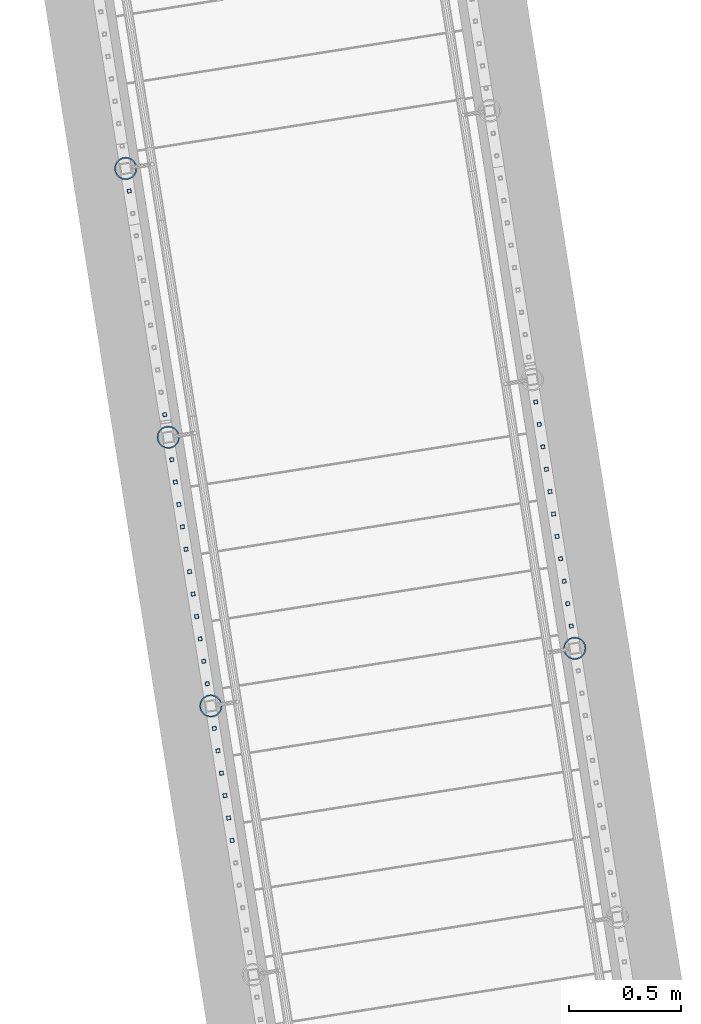
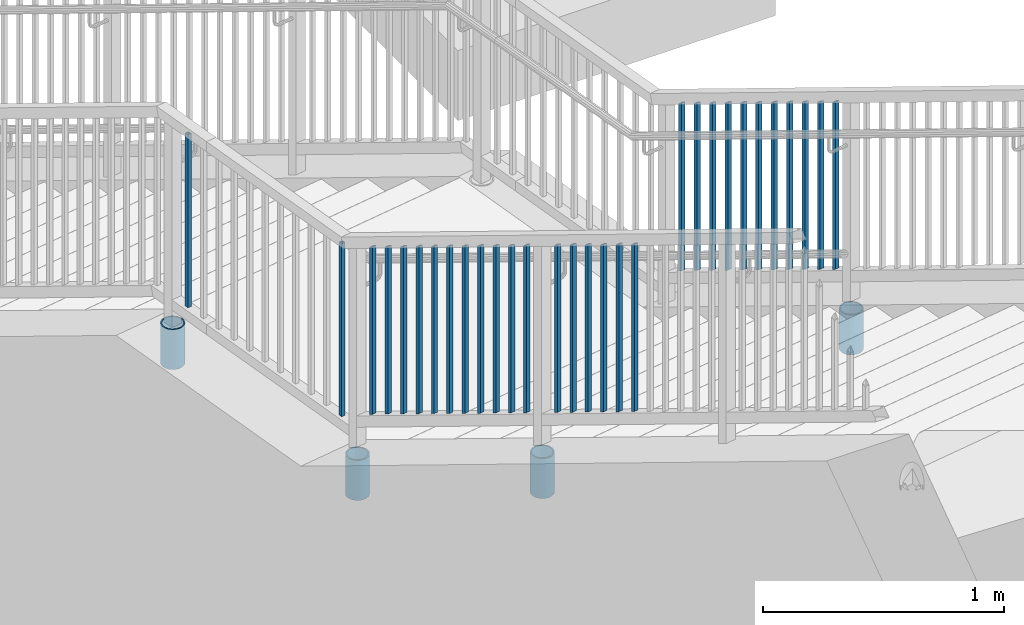
# One storey, part 225 of 975: 34 columns.
"""IFC2X3 building model written with IfcOpenShell, lengths in millimetres."""

from ifc_helpers import new_model, si_unit, frame, origin_with_axes, place, context, subcontext, project, spatial, faceted_brep, material, type_object, element, save


model = new_model("IFC2X3")

# Units and contexts
model_context = context("Model", 3, precision=1e-05, world=origin_with_axes())
body_context = subcontext(model_context, "Body", "Model", "MODEL_VIEW")
ifc_project = project(units=[si_unit("LENGTHUNIT", "METRE", prefix="MILLI"), si_unit("AREAUNIT", "SQUARE_METRE"), si_unit("VOLUMEUNIT", "CUBIC_METRE"), si_unit("MASSUNIT", "GRAM", prefix="KILO"), si_unit("TIMEUNIT", "SECOND"), si_unit("PLANEANGLEUNIT", "RADIAN"), si_unit("SOLIDANGLEUNIT", "STERADIAN"), si_unit("THERMODYNAMICTEMPERATUREUNIT", "DEGREE_CELSIUS"), si_unit("LUMINOUSINTENSITYUNIT", "LUMEN")], contexts=[model_context])

# Site, building, storey
site_placement = place(None, origin_with_axes())
site = spatial("IfcSite", under=ifc_project, at=site_placement, CompositionType="ELEMENT")
building_placement = place(site_placement, origin_with_axes())
building = spatial("IfcBuilding", under=site, at=building_placement, Name="Undefined", CompositionType="ELEMENT")
storey_placement = place(building_placement, origin_with_axes())
storey = spatial("IfcBuildingStorey", under=building, at=storey_placement, Name="Undefined", CompositionType="ELEMENT", Elevation=0.0)

# Columns
ifc_material_1 = material()
column_type_1 = type_object("IfcColumnType", Name="HSS3/4X3/4X.120_TUBES", PredefinedType="NOTDEFINED")
column_1_placement = place(storey_placement, frame((-2139.12873892956, 24109.8690795719, 2159.00006445516), z_axis=(-0.987688340611262, -0.156434464938429, 0.0), x_axis=(0.0, 0.0, 1.0)))
element("IfcColumn", 1, at=column_1_placement, inside=storey, type_object=column_type_1, material=ifc_material_1, Name="PICKET", ObjectType="HSS3/4X3/4X.120_TUBES", context=body_context, shape_type="Brep", body=[
    faceted_brep([(0.0, 6.34999999998763, -6.34999999998763), (0.0, -6.35000000000582, -6.34999999998763), (876.3, -6.35000000000218, -6.3500000000131), (876.3, 6.34999999999854, -6.35000000000946), (0.0, -6.34999999998763, 6.34999999998763), (876.3, -6.34999999999854, 6.34999999999127), (0.0, 6.35000000000946, 6.34999999998763), (876.3, 6.35000000000582, 6.34999999999491), (0.0, 9.52499999997963, -9.52499999997963), (0.0, 9.52500000000873, 9.5249999999869), (876.3, 9.52500000000146, 9.52499999999418), (876.3, 9.52499999999782, -9.52500000001237), (0.0, -9.52499999997963, 9.52499999998327), (876.3, -9.52499999999782, 9.52499999999054), (0.0, -9.52500000000873, -9.5249999999869), (876.3, -9.52500000000146, -9.52500000001237)], [[[0, 1, 2, 3]], [[1, 4, 5, 2]], [[4, 6, 7, 5]], [[6, 0, 3, 7]], [[8, 9, 10, 11]], [[9, 12, 13, 10]], [[12, 14, 15, 13]], [[14, 8, 11, 15]], [[13, 15, 11, 10], [5, 7, 3, 2]], [[14, 12, 9, 8], [6, 4, 1, 0]]]),
])
for number, where, z_axis, x_axis, name in (
    (2, (-317.339031692647, 23162.7377146644, 2852.79542413081), (-0.987688340611262, -0.156434464938429, 0.0), (0.0, 0.0, 1.0), "PICKET"),
    (3, (-333.241567261185, 23263.1423718248, 2796.67272117975), (-0.987688340611262, -0.156434464938429, 0.0), (0.0, 0.0, 1.0), "PICKET"),
    (4, (-349.144102829728, 23363.5470289853, 2740.55001822867), (-0.987688340611262, -0.156434464938429, 0.0), (0.0, 0.0, 1.0), "PICKET"),
    (5, (-365.046638398269, 23463.9516861457, 2684.4273152776), (-0.987688340611262, -0.156434464938429, 0.0), (0.0, 0.0, 1.0), "PICKET"),
    (6, (-380.949173966809, 23564.3563433061, 2628.30461232653), (-0.987688340611262, -0.156434464938429, 0.0), (0.0, 0.0, 1.0), "PICKET"),
    (7, (-396.851709535351, 23664.7610004665, 2572.18190937545), (-0.987688340611262, -0.156434464938429, 0.0), (0.0, 0.0, 1.0), "PICKET"),
    (8, (-412.75424510389, 23765.1656576269, 2516.05920642439), (-0.987688340611262, -0.156434464938429, 0.0), (0.0, 0.0, 1.0), "PICKET"),
    (9, (-428.656780672431, 23865.5703147874, 2459.93650347332), (-0.987688340611262, -0.156434464938429, 0.0), (0.0, 0.0, 1.0), "PICKET"),
    (10, (-444.559316240973, 23965.9749719478, 2403.81380052224), (-0.987688340611262, -0.156434464938429, 0.0), (0.0, 0.0, 1.0), "PICKET"),
    (11, (-460.461851809513, 24066.3796291082, 2347.69109757117), (-0.987688340611262, -0.156434464938429, 0.0), (0.0, 0.0, 1.0), "PICKET"),
    (12, (-476.364387378206, 24166.7842862696, 2291.56839461957), (-0.987688340611262, -0.156434464938429, 0.0), (0.0, 0.0, 1.0), "PICKET"),
):
    element("IfcColumn", number, at=place(storey_placement, frame(where, z_axis=z_axis, x_axis=x_axis)), inside=storey, type_object=column_type_1, material=ifc_material_1, Name=name, ObjectType="HSS3/4X3/4X.120_TUBES", context=body_context, shape_type="Brep", body=[
        faceted_brep([(-17.9916664943412, 6.34999999999491, -6.34999999999945), (-10.9802079664514, -6.34999999999127, -6.35000000000173), (838.195107257512, -6.34999999999491, -6.35000000000082), (831.183648729623, 6.34999999999491, -6.34999999999945), (-10.9802079664505, -6.34999999998763, 6.34999999999764), (838.195107270213, -6.34999999999127, 6.34999999999809), (-17.9916664943403, 6.35000000000218, 6.34999999999945), (831.183648742323, 6.35000000000218, 6.34999999999945), (-19.7445311263136, 9.52499999999054, -9.52499999999918), (-19.7445311263118, 9.52500000000146, 9.52499999999918), (829.430784113527, 9.52499999999782, 9.52499999999964), (829.430784094476, 9.52499999999054, -9.52499999999827), (-9.22734333447806, -9.52499999998327, 9.52499999999691), (839.947971905361, -9.5249999999869, 9.52499999999736), (-9.22734333447897, -9.52499999999418, -9.525000000001), (839.947971886309, -9.52499999999782, -9.525000000001)], [[[0, 1, 2, 3]], [[1, 4, 5, 2]], [[4, 6, 7, 5]], [[6, 0, 3, 7]], [[8, 9, 10, 11]], [[9, 12, 13, 10]], [[12, 14, 15, 13]], [[14, 8, 11, 15]], [[13, 15, 11, 10], [5, 7, 3, 2]], [[14, 12, 9, 8], [6, 4, 1, 0]]]),
    ])
column_2_placement = place(storey_placement, frame((-2297.84832886506, 25111.9832760215, 2158.99369648662), z_axis=(-0.987688340611262, -0.156434464938429, 0.0), x_axis=(0.0, 0.0, 1.0)))
element("IfcColumn", 13, at=column_2_placement, inside=storey, type_object=column_type_1, material=ifc_material_1, Name="PICKET", ObjectType="HSS3/4X3/4X.120_TUBES", context=body_context, shape_type="Brep", body=[
    faceted_brep([(0.0, 6.34999999998763, -6.34999999998763), (0.0, -6.35000000000582, -6.34999999998763), (876.3, -6.35000000000218, -6.3500000000131), (876.3, 6.34999999999854, -6.35000000000946), (0.0, -6.34999999998763, 6.34999999998763), (876.3, -6.34999999999854, 6.34999999999127), (0.0, 6.35000000000946, 6.34999999998763), (876.3, 6.35000000000582, 6.34999999999491), (0.0, 9.52499999997963, -9.52499999997963), (0.0, 9.52500000000873, 9.5249999999869), (876.3, 9.52500000000146, 9.52499999999418), (876.3, 9.52499999999782, -9.52500000001237), (0.0, -9.52499999997963, 9.52499999998327), (876.3, -9.52499999999782, 9.52499999999054), (0.0, -9.52500000000873, -9.5249999999869), (876.3, -9.52500000000146, -9.52500000001237)], [[[0, 1, 2, 3]], [[1, 4, 5, 2]], [[4, 6, 7, 5]], [[6, 0, 3, 7]], [[8, 9, 10, 11]], [[9, 12, 13, 10]], [[12, 14, 15, 13]], [[14, 8, 11, 15]], [[13, 15, 11, 10], [5, 7, 3, 2]], [[14, 12, 9, 8], [6, 4, 1, 0]]]),
])
for number, where, z_axis, x_axis, name in (
    (14, (-1836.99240625921, 22202.2544668497, 3245.28911153992), (-0.987688340611262, -0.156434464938429, 0.0), (0.0, 0.0, 1.0), "PICKET"),
    (15, (-1852.89499688576, 22302.6594716336, 3189.1662142793), (-0.987688340611262, -0.156434464938429, 0.0), (0.0, 0.0, 1.0), "PICKET"),
    (16, (-1868.79758751231, 22403.0644764175, 3133.04331701868), (-0.987688340611262, -0.156434464938429, 0.0), (0.0, 0.0, 1.0), "PICKET"),
    (17, (-1884.70017813885, 22503.4694812015, 3076.92041975807), (-0.987688340611262, -0.156434464938429, 0.0), (0.0, 0.0, 1.0), "PICKET"),
    (18, (-1900.6027687654, 22603.8744859854, 3020.79752249744), (-0.987688340611262, -0.156434464938429, 0.0), (0.0, 0.0, 1.0), "PICKET"),
    (19, (-1916.50535939195, 22704.2794907693, 2964.67462523683), (-0.987688340611262, -0.156434464938429, 0.0), (0.0, 0.0, 1.0), "PICKET"),
    (20, (-1948.20666530578, 22904.4336572622, 2852.79542413081), (-0.987688340611262, -0.156434464938429, 0.0), (0.0, 0.0, 1.0), "PICKET"),
    (21, (-1964.10920087413, 23004.8383144224, 2796.67272117975), (-0.987688340611262, -0.156434464938429, 0.0), (0.0, 0.0, 1.0), "PICKET"),
    (22, (-1980.01173644249, 23105.2429715826, 2740.55001822867), (-0.987688340611262, -0.156434464938429, 0.0), (0.0, 0.0, 1.0), "PICKET"),
    (23, (-1995.91427201085, 23205.6476287427, 2684.4273152776), (-0.987688340611262, -0.156434464938429, 0.0), (0.0, 0.0, 1.0), "PICKET"),
    (24, (-2011.8168075792, 23306.0522859029, 2628.30461232653), (-0.987688340611262, -0.156434464938429, 0.0), (0.0, 0.0, 1.0), "PICKET"),
    (25, (-2027.71934314756, 23406.4569430631, 2572.18190937545), (-0.987688340611262, -0.156434464938429, 0.0), (0.0, 0.0, 1.0), "PICKET"),
    (26, (-2043.62187871592, 23506.8616002233, 2516.05920642439), (-0.987688340611262, -0.156434464938429, 0.0), (0.0, 0.0, 1.0), "PICKET"),
    (27, (-2059.52441428427, 23607.2662573835, 2459.93650347332), (-0.987688340611262, -0.156434464938429, 0.0), (0.0, 0.0, 1.0), "PICKET"),
    (28, (-2075.42694985263, 23707.6709145437, 2403.81380052224), (-0.987688340611262, -0.156434464938429, 0.0), (0.0, 0.0, 1.0), "PICKET"),
    (29, (-2091.32948542099, 23808.0755717038, 2347.69109757117), (-0.987688340611262, -0.156434464938429, 0.0), (0.0, 0.0, 1.0), "PICKET"),
    (30, (-2107.2320209895, 23908.480228865, 2291.56839461957), (-0.987688340611262, -0.156434464938429, 0.0), (0.0, 0.0, 1.0), "PICKET"),
):
    element("IfcColumn", number, at=place(storey_placement, frame(where, z_axis=z_axis, x_axis=x_axis)), inside=storey, type_object=column_type_1, material=ifc_material_1, Name=name, ObjectType="HSS3/4X3/4X.120_TUBES", context=body_context, shape_type="Brep", body=[
        faceted_brep([(-17.9916664943412, 6.34999999999491, -6.34999999999945), (-10.9802079664514, -6.34999999999127, -6.35000000000173), (838.195107257512, -6.34999999999491, -6.35000000000082), (831.183648729623, 6.34999999999491, -6.34999999999945), (-10.9802079664505, -6.34999999998763, 6.34999999999764), (838.195107270213, -6.34999999999127, 6.34999999999809), (-17.9916664943403, 6.35000000000218, 6.34999999999945), (831.183648742323, 6.35000000000218, 6.34999999999945), (-19.7445311263136, 9.52499999999054, -9.52499999999918), (-19.7445311263118, 9.52500000000146, 9.52499999999918), (829.430784113527, 9.52499999999782, 9.52499999999964), (829.430784094476, 9.52499999999054, -9.52499999999827), (-9.22734333447806, -9.52499999998327, 9.52499999999691), (839.947971905361, -9.5249999999869, 9.52499999999736), (-9.22734333447897, -9.52499999999418, -9.525000000001), (839.947971886309, -9.52499999999782, -9.525000000001)], [[[0, 1, 2, 3]], [[1, 4, 5, 2]], [[4, 6, 7, 5]], [[6, 0, 3, 7]], [[8, 9, 10, 11]], [[9, 12, 13, 10]], [[12, 14, 15, 13]], [[14, 8, 11, 15]], [[13, 15, 11, 10], [5, 7, 3, 2]], [[14, 12, 9, 8], [6, 4, 1, 0]]]),
    ])
ifc_material_2 = material(Name="STEEL/A53")
column_type_2 = type_object("IfcColumnType", Name="PIPE3-1/2STD", PredefinedType="NOTDEFINED")
column_3_placement = place(storey_placement, frame((-301.5410487228, 23062.9884370635, 2489.20008401159), z_axis=(0.587785252279345, 0.809016994384486, -8.09014238711826e-10), x_axis=(0.0, 0.0, 1.0)))
element("IfcColumn", 31, at=column_3_placement, inside=storey, type_object=column_type_2, material=ifc_material_2, ObjectType="PIPE3-1/2STD", context=body_context, shape_type="Brep", body=[
    faceted_brep([(0.0, -45.0595999999932, 1.45519152283669e-11), (0.0, -42.8542262016344, 13.924182159768), (203.199999999991, -42.8542262017145, 13.9241821598171), (203.19999999999, -45.0596000000478, 5.82076609134674e-11), (0.0, -36.45398215971, 26.4853683542424), (203.199999999993, -36.45398215981, 26.4853683542988), (0.0, -26.4853683541623, 36.45398215979), (203.199999999995, -26.4853683542788, 36.4539821598537), (0.0, -13.9241821596988, 42.8542262017108), (203.199999999998, -13.9241821598262, 42.8542262017836), (0.0, 3.63797880709171e-11, 45.0596000000514), (203.2, -9.27684595808387e-11, 45.0596000001387), (0.0, 13.9241821597716, 42.8542262017036), (203.200000000003, 13.9241821596443, 42.8542262017927), (0.0, 26.4853683542242, 36.4539821597718), (203.200000000006, 26.4853683541096, 36.4539821598701), (0.0, 36.4539821597537, 26.4853683542206), (203.200000000008, 36.4539821596554, 26.4853683543224), (0.0, 42.8542262016563, 13.9241821597425), (203.200000000009, 42.8542262015817, 13.9241821598443), (0.0, 45.0595999999932, -1.09139364212751e-11), (203.200000000009, 45.0595999999423, 8.9130480773747e-11), (0.0, 42.8542262016344, -13.9241821597643), (203.200000000008, 42.854226201609, -13.9241821596697), (0.0, 36.45398215971, -26.4853683542387), (203.200000000007, 36.4539821597045, -26.4853683541514), (0.0, 26.4853683541623, -36.4539821597864), (203.200000000004, 26.4853683541733, -36.4539821597064), (0.0, 13.9241821596988, -42.8542262017072), (203.200000000002, 13.9241821597225, -42.8542262016381), (0.0, -3.63797880709171e-11, -45.0596000000478), (203.199999999999, -9.09494701772928e-12, -45.0595999999914), (0.0, -13.9241821597716, -42.8542262016963), (203.199999999996, -13.9241821597479, -42.8542262016472), (0.0, -26.4853683542242, -36.4539821597682), (203.199999999993, -26.4853683542133, -36.4539821597227), (0.0, -36.4539821597537, -26.4853683542169), (203.199999999992, -36.4539821597609, -26.4853683541751), (0.0, -42.8542262016563, -13.9241821597352), (203.199999999991, -42.8542262016872, -13.924182159697), (0.0, -50.799999999992, 1.81898940354586e-11), (0.0, -48.3136710278013, -15.6980633142484), (203.199999999989, -48.313671027825, -15.6980633142139), (203.199999999989, -50.8000000000466, 5.63886715099216e-11), (0.0, -41.0980633142644, -29.8594908164741), (203.19999999999, -41.0980633142663, -29.8594908164414), (0.0, -29.859490816485, -41.0980633142826), (203.199999999993, -29.8594908164687, -41.0980633142426), (0.0, -15.6980633142848, -48.313671027845), (203.199999999995, -15.6980633142539, -48.313671027794), (0.0, -4.36557456851006e-11, -50.8000000000575), (203.199999999998, -7.27595761418343e-12, -50.7999999999993), (0.0, 15.6980633142011, -48.3136710278523), (203.200000000002, 15.6980633142375, -48.3136710277831), (0.0, 29.8594908164159, -41.0980633143045), (203.200000000005, 29.8594908164378, -41.0980633142226), (0.0, 41.0980633142135, -29.8594908165032), (203.200000000008, 41.0980633142171, -29.8594908164141), (0.0, 48.3136710277722, -15.6980633142775), (203.200000000009, 48.3136710277504, -15.6980633141811), (0.0, 50.799999999992, -1.45519152283669e-11), (203.20000000001, 50.7999999999411, 9.09494701772928e-11), (0.0, 48.313671027794, 15.6980633142521), (203.20000000001, 48.3136710277213, 15.6980633143594), (0.0, 41.0980633142644, 29.8594908164814), (203.200000000008, 41.0980633141626, 29.8594908165887), (0.0, 29.859490816485, 41.0980633142863), (203.200000000007, 29.8594908163632, 41.0980633143899), (0.0, 15.6980633142848, 48.3136710278486), (203.200000000004, 15.6980633141484, 48.3136710279414), (0.0, 4.00177668780088e-11, 50.8000000000611), (203.200000000001, -9.82254277914762e-11, 50.8000000001466), (0.0, -15.6980633142011, 48.3136710278559), (203.199999999997, -15.698063314343, 48.3136710279305), (0.0, -29.8594908164159, 41.0980633143081), (203.199999999994, -29.8594908165433, 41.0980633143681), (0.0, -41.0980633142171, 29.8594908165069), (203.199999999992, -41.0980633143226, 29.8594908165596), (0.0, -48.3136710277722, 15.6980633142812), (203.19999999999, -48.3136710278559, 15.6980633143285)], [[[0, 1, 2, 3]], [[1, 4, 5, 2]], [[4, 6, 7, 5]], [[6, 8, 9, 7]], [[8, 10, 11, 9]], [[10, 12, 13, 11]], [[12, 14, 15, 13]], [[14, 16, 17, 15]], [[16, 18, 19, 17]], [[18, 20, 21, 19]], [[20, 22, 23, 21]], [[22, 24, 25, 23]], [[24, 26, 27, 25]], [[26, 28, 29, 27]], [[28, 30, 31, 29]], [[30, 32, 33, 31]], [[32, 34, 35, 33]], [[34, 36, 37, 35]], [[36, 38, 39, 37]], [[38, 0, 3, 39]], [[40, 41, 42, 43]], [[41, 44, 45, 42]], [[44, 46, 47, 45]], [[46, 48, 49, 47]], [[48, 50, 51, 49]], [[50, 52, 53, 51]], [[52, 54, 55, 53]], [[54, 56, 57, 55]], [[56, 58, 59, 57]], [[58, 60, 61, 59]], [[60, 62, 63, 61]], [[62, 64, 65, 63]], [[64, 66, 67, 65]], [[66, 68, 69, 67]], [[68, 70, 71, 69]], [[70, 72, 73, 71]], [[72, 74, 75, 73]], [[74, 76, 77, 75]], [[76, 78, 79, 77]], [[78, 40, 43, 79]], [[45, 47, 49, 51, 53, 55, 57, 59, 61, 63, 65, 67, 69, 71, 73, 75, 77, 79, 43, 42], [5, 7, 9, 11, 13, 15, 17, 19, 21, 23, 25, 27, 29, 31, 33, 35, 37, 39, 3, 2]], [[78, 76, 74, 72, 70, 68, 66, 64, 62, 60, 58, 56, 54, 52, 50, 48, 46, 44, 41, 40], [38, 36, 34, 32, 30, 28, 26, 24, 22, 20, 18, 16, 14, 12, 10, 8, 6, 4, 1, 0]]]),
])
column_4_placement = place(storey_placement, frame((-2313.85770652054, 25213.0635535687, 1816.09994848937), z_axis=(-0.587785252279345, -0.809016994384486, -8.09014181868407e-10), x_axis=(0.0, 0.0, 1.0)))
element("IfcColumn", 32, at=column_4_placement, inside=storey, type_object=column_type_2, material=ifc_material_2, ObjectType="PIPE3-1/2STD", context=body_context, shape_type="Brep", body=[
    faceted_brep([(0.0, -45.0595999999932, 1.45519152283669e-11), (0.0, -42.8542262016344, 13.924182159768), (203.199999999991, -42.8542262017145, 13.9241821598171), (203.19999999999, -45.0596000000478, 5.82076609134674e-11), (0.0, -36.45398215971, 26.4853683542424), (203.199999999993, -36.45398215981, 26.4853683542988), (0.0, -26.4853683541623, 36.45398215979), (203.199999999995, -26.4853683542788, 36.4539821598537), (0.0, -13.9241821596988, 42.8542262017108), (203.199999999998, -13.9241821598262, 42.8542262017836), (0.0, 3.63797880709171e-11, 45.0596000000514), (203.2, -9.27684595808387e-11, 45.0596000001387), (0.0, 13.9241821597716, 42.8542262017036), (203.200000000003, 13.9241821596443, 42.8542262017927), (0.0, 26.4853683542242, 36.4539821597718), (203.200000000006, 26.4853683541096, 36.4539821598701), (0.0, 36.4539821597537, 26.4853683542206), (203.200000000008, 36.4539821596554, 26.4853683543224), (0.0, 42.8542262016563, 13.9241821597425), (203.200000000009, 42.8542262015817, 13.9241821598443), (0.0, 45.0595999999932, -1.09139364212751e-11), (203.200000000009, 45.0595999999423, 8.9130480773747e-11), (0.0, 42.8542262016344, -13.9241821597643), (203.200000000008, 42.854226201609, -13.9241821596697), (0.0, 36.45398215971, -26.4853683542387), (203.200000000007, 36.4539821597045, -26.4853683541514), (0.0, 26.4853683541623, -36.4539821597864), (203.200000000004, 26.4853683541733, -36.4539821597064), (0.0, 13.9241821596988, -42.8542262017072), (203.200000000002, 13.9241821597225, -42.8542262016381), (0.0, -3.63797880709171e-11, -45.0596000000478), (203.199999999999, -9.09494701772928e-12, -45.0595999999914), (0.0, -13.9241821597716, -42.8542262016963), (203.199999999996, -13.9241821597479, -42.8542262016472), (0.0, -26.4853683542242, -36.4539821597682), (203.199999999993, -26.4853683542133, -36.4539821597227), (0.0, -36.4539821597537, -26.4853683542169), (203.199999999992, -36.4539821597609, -26.4853683541751), (0.0, -42.8542262016563, -13.9241821597352), (203.199999999991, -42.8542262016872, -13.924182159697), (0.0, -50.799999999992, 1.81898940354586e-11), (0.0, -48.3136710278013, -15.6980633142484), (203.199999999989, -48.313671027825, -15.6980633142139), (203.199999999989, -50.8000000000466, 5.63886715099216e-11), (0.0, -41.0980633142644, -29.8594908164741), (203.19999999999, -41.0980633142663, -29.8594908164414), (0.0, -29.859490816485, -41.0980633142826), (203.199999999993, -29.8594908164687, -41.0980633142426), (0.0, -15.6980633142848, -48.313671027845), (203.199999999995, -15.6980633142539, -48.313671027794), (0.0, -4.36557456851006e-11, -50.8000000000575), (203.199999999998, -7.27595761418343e-12, -50.7999999999993), (0.0, 15.6980633142011, -48.3136710278523), (203.200000000002, 15.6980633142375, -48.3136710277831), (0.0, 29.8594908164159, -41.0980633143045), (203.200000000005, 29.8594908164378, -41.0980633142226), (0.0, 41.0980633142135, -29.8594908165032), (203.200000000008, 41.0980633142171, -29.8594908164141), (0.0, 48.3136710277722, -15.6980633142775), (203.200000000009, 48.3136710277504, -15.6980633141811), (0.0, 50.799999999992, -1.45519152283669e-11), (203.20000000001, 50.7999999999411, 9.09494701772928e-11), (0.0, 48.313671027794, 15.6980633142521), (203.20000000001, 48.3136710277213, 15.6980633143594), (0.0, 41.0980633142644, 29.8594908164814), (203.200000000008, 41.0980633141626, 29.8594908165887), (0.0, 29.859490816485, 41.0980633142863), (203.200000000007, 29.8594908163632, 41.0980633143899), (0.0, 15.6980633142848, 48.3136710278486), (203.200000000004, 15.6980633141484, 48.3136710279414), (0.0, 4.00177668780088e-11, 50.8000000000611), (203.200000000001, -9.82254277914762e-11, 50.8000000001466), (0.0, -15.6980633142011, 48.3136710278559), (203.199999999997, -15.698063314343, 48.3136710279305), (0.0, -29.8594908164159, 41.0980633143081), (203.199999999994, -29.8594908165433, 41.0980633143681), (0.0, -41.0980633142171, 29.8594908165069), (203.199999999992, -41.0980633143226, 29.8594908165596), (0.0, -48.3136710277722, 15.6980633142812), (203.19999999999, -48.3136710278559, 15.6980633143285)], [[[0, 1, 2, 3]], [[1, 4, 5, 2]], [[4, 6, 7, 5]], [[6, 8, 9, 7]], [[8, 10, 11, 9]], [[10, 12, 13, 11]], [[12, 14, 15, 13]], [[14, 16, 17, 15]], [[16, 18, 19, 17]], [[18, 20, 21, 19]], [[20, 22, 23, 21]], [[22, 24, 25, 23]], [[24, 26, 27, 25]], [[26, 28, 29, 27]], [[28, 30, 31, 29]], [[30, 32, 33, 31]], [[32, 34, 35, 33]], [[34, 36, 37, 35]], [[36, 38, 39, 37]], [[38, 0, 3, 39]], [[40, 41, 42, 43]], [[41, 44, 45, 42]], [[44, 46, 47, 45]], [[46, 48, 49, 47]], [[48, 50, 51, 49]], [[50, 52, 53, 51]], [[52, 54, 55, 53]], [[54, 56, 57, 55]], [[56, 58, 59, 57]], [[58, 60, 61, 59]], [[60, 62, 63, 61]], [[62, 64, 65, 63]], [[64, 66, 67, 65]], [[66, 68, 69, 67]], [[68, 70, 71, 69]], [[70, 72, 73, 71]], [[72, 74, 75, 73]], [[74, 76, 77, 75]], [[76, 78, 79, 77]], [[78, 40, 43, 79]], [[45, 47, 49, 51, 53, 55, 57, 59, 61, 63, 65, 67, 69, 71, 73, 75, 77, 79, 43, 42], [5, 7, 9, 11, 13, 15, 17, 19, 21, 23, 25, 27, 29, 31, 33, 35, 37, 39, 3, 2]], [[78, 76, 74, 72, 70, 68, 66, 64, 62, 60, 58, 56, 54, 52, 50, 48, 46, 44, 41, 40], [38, 36, 34, 32, 30, 28, 26, 24, 22, 20, 18, 16, 14, 12, 10, 8, 6, 4, 1, 0]]]),
])
column_5_placement = place(storey_placement, frame((-2123.13157774047, 24008.8661682944, 1816.09988445631), z_axis=(-0.587785252279345, -0.809016994384486, -8.09014181868407e-10), x_axis=(0.0, 0.0, 1.0)))
element("IfcColumn", 33, at=column_5_placement, inside=storey, type_object=column_type_2, material=ifc_material_2, ObjectType="PIPE3-1/2STD", context=body_context, shape_type="Brep", body=[
    faceted_brep([(0.0, -45.0595999999932, 1.45519152283669e-11), (0.0, -42.8542262016344, 13.924182159768), (203.199999999991, -42.8542262017145, 13.9241821598171), (203.19999999999, -45.0596000000478, 5.82076609134674e-11), (0.0, -36.45398215971, 26.4853683542424), (203.199999999993, -36.45398215981, 26.4853683542988), (0.0, -26.4853683541623, 36.45398215979), (203.199999999995, -26.4853683542788, 36.4539821598537), (0.0, -13.9241821596988, 42.8542262017108), (203.199999999998, -13.9241821598262, 42.8542262017836), (0.0, 3.63797880709171e-11, 45.0596000000514), (203.2, -9.27684595808387e-11, 45.0596000001387), (0.0, 13.9241821597716, 42.8542262017036), (203.200000000003, 13.9241821596443, 42.8542262017927), (0.0, 26.4853683542242, 36.4539821597718), (203.200000000006, 26.4853683541096, 36.4539821598701), (0.0, 36.4539821597537, 26.4853683542206), (203.200000000008, 36.4539821596554, 26.4853683543224), (0.0, 42.8542262016563, 13.9241821597425), (203.200000000009, 42.8542262015817, 13.9241821598443), (0.0, 45.0595999999932, -1.09139364212751e-11), (203.200000000009, 45.0595999999423, 8.9130480773747e-11), (0.0, 42.8542262016344, -13.9241821597643), (203.200000000008, 42.854226201609, -13.9241821596697), (0.0, 36.45398215971, -26.4853683542387), (203.200000000007, 36.4539821597045, -26.4853683541514), (0.0, 26.4853683541623, -36.4539821597864), (203.200000000004, 26.4853683541733, -36.4539821597064), (0.0, 13.9241821596988, -42.8542262017072), (203.200000000002, 13.9241821597225, -42.8542262016381), (0.0, -3.63797880709171e-11, -45.0596000000478), (203.199999999999, -9.09494701772928e-12, -45.0595999999914), (0.0, -13.9241821597716, -42.8542262016963), (203.199999999996, -13.9241821597479, -42.8542262016472), (0.0, -26.4853683542242, -36.4539821597682), (203.199999999993, -26.4853683542133, -36.4539821597227), (0.0, -36.4539821597537, -26.4853683542169), (203.199999999992, -36.4539821597609, -26.4853683541751), (0.0, -42.8542262016563, -13.9241821597352), (203.199999999991, -42.8542262016872, -13.924182159697), (0.0, -50.799999999992, 1.81898940354586e-11), (0.0, -48.3136710278013, -15.6980633142484), (203.199999999989, -48.313671027825, -15.6980633142139), (203.199999999989, -50.8000000000466, 5.63886715099216e-11), (0.0, -41.0980633142644, -29.8594908164741), (203.19999999999, -41.0980633142663, -29.8594908164414), (0.0, -29.859490816485, -41.0980633142826), (203.199999999993, -29.8594908164687, -41.0980633142426), (0.0, -15.6980633142848, -48.313671027845), (203.199999999995, -15.6980633142539, -48.313671027794), (0.0, -4.36557456851006e-11, -50.8000000000575), (203.199999999998, -7.27595761418343e-12, -50.7999999999993), (0.0, 15.6980633142011, -48.3136710278523), (203.200000000002, 15.6980633142375, -48.3136710277831), (0.0, 29.8594908164159, -41.0980633143045), (203.200000000005, 29.8594908164378, -41.0980633142226), (0.0, 41.0980633142135, -29.8594908165032), (203.200000000008, 41.0980633142171, -29.8594908164141), (0.0, 48.3136710277722, -15.6980633142775), (203.200000000009, 48.3136710277504, -15.6980633141811), (0.0, 50.799999999992, -1.45519152283669e-11), (203.20000000001, 50.7999999999411, 9.09494701772928e-11), (0.0, 48.313671027794, 15.6980633142521), (203.20000000001, 48.3136710277213, 15.6980633143594), (0.0, 41.0980633142644, 29.8594908164814), (203.200000000008, 41.0980633141626, 29.8594908165887), (0.0, 29.859490816485, 41.0980633142863), (203.200000000007, 29.8594908163632, 41.0980633143899), (0.0, 15.6980633142848, 48.3136710278486), (203.200000000004, 15.6980633141484, 48.3136710279414), (0.0, 4.00177668780088e-11, 50.8000000000611), (203.200000000001, -9.82254277914762e-11, 50.8000000001466), (0.0, -15.6980633142011, 48.3136710278559), (203.199999999997, -15.698063314343, 48.3136710279305), (0.0, -29.8594908164159, 41.0980633143081), (203.199999999994, -29.8594908165433, 41.0980633143681), (0.0, -41.0980633142171, 29.8594908165069), (203.199999999992, -41.0980633143226, 29.8594908165596), (0.0, -48.3136710277722, 15.6980633142812), (203.19999999999, -48.3136710278559, 15.6980633143285)], [[[0, 1, 2, 3]], [[1, 4, 5, 2]], [[4, 6, 7, 5]], [[6, 8, 9, 7]], [[8, 10, 11, 9]], [[10, 12, 13, 11]], [[12, 14, 15, 13]], [[14, 16, 17, 15]], [[16, 18, 19, 17]], [[18, 20, 21, 19]], [[20, 22, 23, 21]], [[22, 24, 25, 23]], [[24, 26, 27, 25]], [[26, 28, 29, 27]], [[28, 30, 31, 29]], [[30, 32, 33, 31]], [[32, 34, 35, 33]], [[34, 36, 37, 35]], [[36, 38, 39, 37]], [[38, 0, 3, 39]], [[40, 41, 42, 43]], [[41, 44, 45, 42]], [[44, 46, 47, 45]], [[46, 48, 49, 47]], [[48, 50, 51, 49]], [[50, 52, 53, 51]], [[52, 54, 55, 53]], [[54, 56, 57, 55]], [[56, 58, 59, 57]], [[58, 60, 61, 59]], [[60, 62, 63, 61]], [[62, 64, 65, 63]], [[64, 66, 67, 65]], [[66, 68, 69, 67]], [[68, 70, 71, 69]], [[70, 72, 73, 71]], [[72, 74, 75, 73]], [[74, 76, 77, 75]], [[76, 78, 79, 77]], [[78, 40, 43, 79]], [[45, 47, 49, 51, 53, 55, 57, 59, 61, 63, 65, 67, 69, 71, 73, 75, 77, 79, 43, 42], [5, 7, 9, 11, 13, 15, 17, 19, 21, 23, 25, 27, 29, 31, 33, 35, 37, 39, 3, 2]], [[78, 76, 74, 72, 70, 68, 66, 64, 62, 60, 58, 56, 54, 52, 50, 48, 46, 44, 41, 40], [38, 36, 34, 32, 30, 28, 26, 24, 22, 20, 18, 16, 14, 12, 10, 8, 6, 4, 1, 0]]]),
])
column_6_placement = place(storey_placement, frame((-1932.40793688369, 22804.6844911497, 2489.20008401159), z_axis=(-0.587785252279345, -0.809016994384486, -8.09014181868407e-10), x_axis=(0.0, 0.0, 1.0)))
element("IfcColumn", 34, at=column_6_placement, inside=storey, type_object=column_type_2, material=ifc_material_2, ObjectType="PIPE3-1/2STD", context=body_context, shape_type="Brep", body=[
    faceted_brep([(0.0, -45.0595999999932, 1.45519152283669e-11), (0.0, -42.8542262016344, 13.924182159768), (203.199999999991, -42.8542262017145, 13.9241821598171), (203.19999999999, -45.0596000000478, 5.82076609134674e-11), (0.0, -36.45398215971, 26.4853683542424), (203.199999999993, -36.45398215981, 26.4853683542988), (0.0, -26.4853683541623, 36.45398215979), (203.199999999995, -26.4853683542788, 36.4539821598537), (0.0, -13.9241821596988, 42.8542262017108), (203.199999999998, -13.9241821598262, 42.8542262017836), (0.0, 3.63797880709171e-11, 45.0596000000514), (203.2, -9.27684595808387e-11, 45.0596000001387), (0.0, 13.9241821597716, 42.8542262017036), (203.200000000003, 13.9241821596443, 42.8542262017927), (0.0, 26.4853683542242, 36.4539821597718), (203.200000000006, 26.4853683541096, 36.4539821598701), (0.0, 36.4539821597537, 26.4853683542206), (203.200000000008, 36.4539821596554, 26.4853683543224), (0.0, 42.8542262016563, 13.9241821597425), (203.200000000009, 42.8542262015817, 13.9241821598443), (0.0, 45.0595999999932, -1.09139364212751e-11), (203.200000000009, 45.0595999999423, 8.9130480773747e-11), (0.0, 42.8542262016344, -13.9241821597643), (203.200000000008, 42.854226201609, -13.9241821596697), (0.0, 36.45398215971, -26.4853683542387), (203.200000000007, 36.4539821597045, -26.4853683541514), (0.0, 26.4853683541623, -36.4539821597864), (203.200000000004, 26.4853683541733, -36.4539821597064), (0.0, 13.9241821596988, -42.8542262017072), (203.200000000002, 13.9241821597225, -42.8542262016381), (0.0, -3.63797880709171e-11, -45.0596000000478), (203.199999999999, -9.09494701772928e-12, -45.0595999999914), (0.0, -13.9241821597716, -42.8542262016963), (203.199999999996, -13.9241821597479, -42.8542262016472), (0.0, -26.4853683542242, -36.4539821597682), (203.199999999993, -26.4853683542133, -36.4539821597227), (0.0, -36.4539821597537, -26.4853683542169), (203.199999999992, -36.4539821597609, -26.4853683541751), (0.0, -42.8542262016563, -13.9241821597352), (203.199999999991, -42.8542262016872, -13.924182159697), (0.0, -50.799999999992, 1.81898940354586e-11), (0.0, -48.3136710278013, -15.6980633142484), (203.199999999989, -48.313671027825, -15.6980633142139), (203.199999999989, -50.8000000000466, 5.63886715099216e-11), (0.0, -41.0980633142644, -29.8594908164741), (203.19999999999, -41.0980633142663, -29.8594908164414), (0.0, -29.859490816485, -41.0980633142826), (203.199999999993, -29.8594908164687, -41.0980633142426), (0.0, -15.6980633142848, -48.313671027845), (203.199999999995, -15.6980633142539, -48.313671027794), (0.0, -4.36557456851006e-11, -50.8000000000575), (203.199999999998, -7.27595761418343e-12, -50.7999999999993), (0.0, 15.6980633142011, -48.3136710278523), (203.200000000002, 15.6980633142375, -48.3136710277831), (0.0, 29.8594908164159, -41.0980633143045), (203.200000000005, 29.8594908164378, -41.0980633142226), (0.0, 41.0980633142135, -29.8594908165032), (203.200000000008, 41.0980633142171, -29.8594908164141), (0.0, 48.3136710277722, -15.6980633142775), (203.200000000009, 48.3136710277504, -15.6980633141811), (0.0, 50.799999999992, -1.45519152283669e-11), (203.20000000001, 50.7999999999411, 9.09494701772928e-11), (0.0, 48.313671027794, 15.6980633142521), (203.20000000001, 48.3136710277213, 15.6980633143594), (0.0, 41.0980633142644, 29.8594908164814), (203.200000000008, 41.0980633141626, 29.8594908165887), (0.0, 29.859490816485, 41.0980633142863), (203.200000000007, 29.8594908163632, 41.0980633143899), (0.0, 15.6980633142848, 48.3136710278486), (203.200000000004, 15.6980633141484, 48.3136710279414), (0.0, 4.00177668780088e-11, 50.8000000000611), (203.200000000001, -9.82254277914762e-11, 50.8000000001466), (0.0, -15.6980633142011, 48.3136710278559), (203.199999999997, -15.698063314343, 48.3136710279305), (0.0, -29.8594908164159, 41.0980633143081), (203.199999999994, -29.8594908165433, 41.0980633143681), (0.0, -41.0980633142171, 29.8594908165069), (203.199999999992, -41.0980633143226, 29.8594908165596), (0.0, -48.3136710277722, 15.6980633142812), (203.19999999999, -48.3136710278559, 15.6980633143285)], [[[0, 1, 2, 3]], [[1, 4, 5, 2]], [[4, 6, 7, 5]], [[6, 8, 9, 7]], [[8, 10, 11, 9]], [[10, 12, 13, 11]], [[12, 14, 15, 13]], [[14, 16, 17, 15]], [[16, 18, 19, 17]], [[18, 20, 21, 19]], [[20, 22, 23, 21]], [[22, 24, 25, 23]], [[24, 26, 27, 25]], [[26, 28, 29, 27]], [[28, 30, 31, 29]], [[30, 32, 33, 31]], [[32, 34, 35, 33]], [[34, 36, 37, 35]], [[36, 38, 39, 37]], [[38, 0, 3, 39]], [[40, 41, 42, 43]], [[41, 44, 45, 42]], [[44, 46, 47, 45]], [[46, 48, 49, 47]], [[48, 50, 51, 49]], [[50, 52, 53, 51]], [[52, 54, 55, 53]], [[54, 56, 57, 55]], [[56, 58, 59, 57]], [[58, 60, 61, 59]], [[60, 62, 63, 61]], [[62, 64, 65, 63]], [[64, 66, 67, 65]], [[66, 68, 69, 67]], [[68, 70, 71, 69]], [[70, 72, 73, 71]], [[72, 74, 75, 73]], [[74, 76, 77, 75]], [[76, 78, 79, 77]], [[78, 40, 43, 79]], [[45, 47, 49, 51, 53, 55, 57, 59, 61, 63, 65, 67, 69, 71, 73, 75, 77, 79, 43, 42], [5, 7, 9, 11, 13, 15, 17, 19, 21, 23, 25, 27, 29, 31, 33, 35, 37, 39, 3, 2]], [[78, 76, 74, 72, 70, 68, 66, 64, 62, 60, 58, 56, 54, 52, 50, 48, 46, 44, 41, 40], [38, 36, 34, 32, 30, 28, 26, 24, 22, 20, 18, 16, 14, 12, 10, 8, 6, 4, 1, 0]]]),
])

save(model, "model.ifc")
